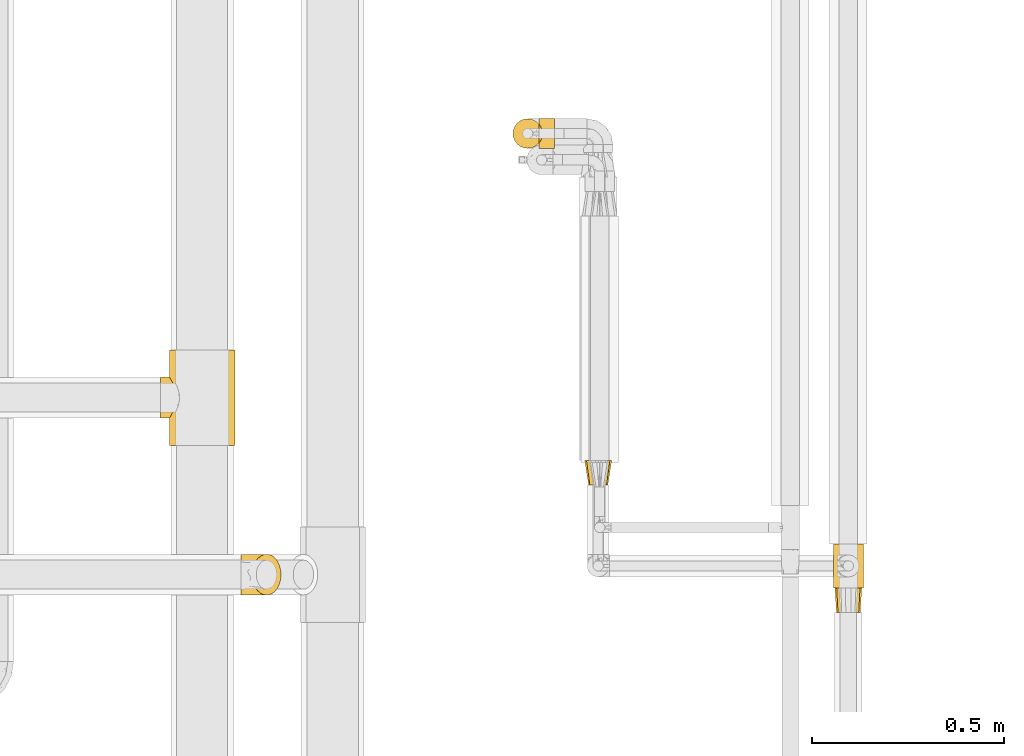
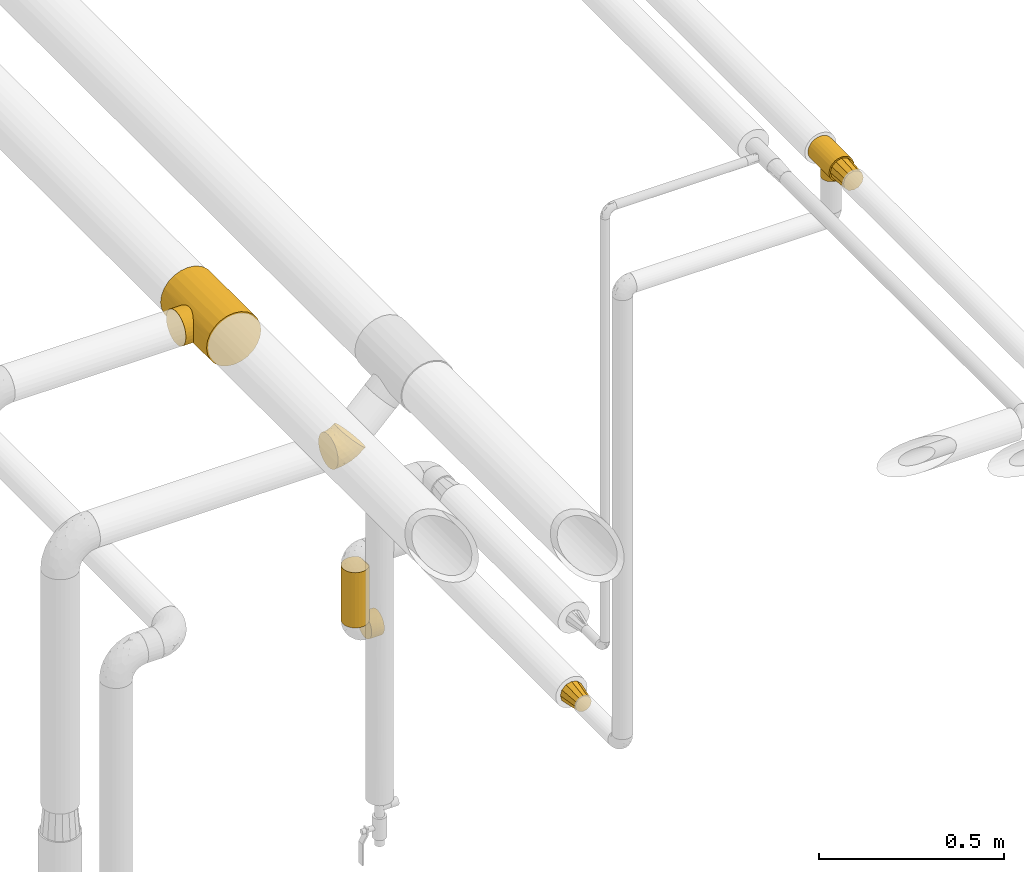
# One storey, part 113 of 827: 7 coverings.
"""IFC2X3 building model written with IfcOpenShell, lengths in millimetres."""

from ifc_helpers import new_model, entity, si_unit, converted_unit, derived_unit, direction, frame, origin, place, context, subcontext, project, spatial, faceted_brep, element, save


model = new_model("IFC2X3")

# Units and contexts
model_context = context("Model", 3, precision=0.01, world=origin(), true_north=direction((6.12303176911189e-17, 1.0)))
body_context = subcontext(model_context, "Body", "Model", "MODEL_VIEW")
ifc_project = project(units=[si_unit("LENGTHUNIT", "METRE", prefix="MILLI"), si_unit("AREAUNIT", "SQUARE_METRE"), si_unit("VOLUMEUNIT", "CUBIC_METRE"), converted_unit("PLANEANGLEUNIT", "DEGREE", entity("IfcRatioMeasure", 0.0174532925199433), si_unit("PLANEANGLEUNIT", "RADIAN"), dimensions=[0, 0, 0, 0, 0, 0, 0]), si_unit("MASSUNIT", "GRAM", prefix="KILO"), derived_unit("MASSDENSITYUNIT", [(si_unit("MASSUNIT", "GRAM", prefix="KILO"), 1), (si_unit("LENGTHUNIT", "METRE"), -3)]), derived_unit("MOMENTOFINERTIAUNIT", [(si_unit("LENGTHUNIT", "METRE"), 4)]), si_unit("TIMEUNIT", "SECOND"), si_unit("FREQUENCYUNIT", "HERTZ"), si_unit("THERMODYNAMICTEMPERATUREUNIT", "DEGREE_CELSIUS"), derived_unit("THERMALTRANSMITTANCEUNIT", [(si_unit("MASSUNIT", "GRAM", prefix="KILO"), 1), (si_unit("THERMODYNAMICTEMPERATUREUNIT", "KELVIN"), -1), (si_unit("TIMEUNIT", "SECOND"), -3)]), derived_unit("VOLUMETRICFLOWRATEUNIT", [(si_unit("LENGTHUNIT", "METRE"), 3), (si_unit("TIMEUNIT", "SECOND"), -1)]), derived_unit("MASSFLOWRATEUNIT", [(si_unit("MASSUNIT", "GRAM", prefix="KILO"), 1), (si_unit("TIMEUNIT", "SECOND"), -1)]), derived_unit("ROTATIONALFREQUENCYUNIT", [(si_unit("TIMEUNIT", "SECOND"), -1)]), si_unit("ELECTRICCURRENTUNIT", "AMPERE"), si_unit("ELECTRICVOLTAGEUNIT", "VOLT"), si_unit("POWERUNIT", "WATT"), si_unit("FORCEUNIT", "NEWTON", prefix="KILO"), si_unit("ILLUMINANCEUNIT", "LUX"), si_unit("LUMINOUSFLUXUNIT", "LUMEN"), si_unit("LUMINOUSINTENSITYUNIT", "CANDELA"), derived_unit("USERDEFINED", [(si_unit("MASSUNIT", "GRAM", prefix="KILO"), -1), (si_unit("LENGTHUNIT", "METRE"), -2), (si_unit("TIMEUNIT", "SECOND"), 3), (si_unit("LUMINOUSFLUXUNIT", "LUMEN"), 1)]), derived_unit("LINEARVELOCITYUNIT", [(si_unit("LENGTHUNIT", "METRE"), 1), (si_unit("TIMEUNIT", "SECOND"), -1)]), si_unit("PRESSUREUNIT", "PASCAL"), derived_unit("USERDEFINED", [(si_unit("LENGTHUNIT", "METRE"), -2), (si_unit("MASSUNIT", "GRAM", prefix="KILO"), 1), (si_unit("TIMEUNIT", "SECOND"), -2)]), derived_unit("LINEARFORCEUNIT", [(si_unit("MASSUNIT", "GRAM", prefix="KILO"), 1), (si_unit("LENGTHUNIT", "METRE"), 1), (si_unit("TIMEUNIT", "SECOND"), -2), (si_unit("LENGTHUNIT", "METRE"), -1)]), derived_unit("PLANARFORCEUNIT", [(si_unit("MASSUNIT", "GRAM", prefix="KILO"), 1), (si_unit("LENGTHUNIT", "METRE"), 1), (si_unit("TIMEUNIT", "SECOND"), -2), (si_unit("LENGTHUNIT", "METRE"), -2)])], contexts=[model_context])

# Site, building, storey
site_placement = place(None, origin())
site = spatial("IfcSite", under=ifc_project, at=site_placement, CompositionType="ELEMENT")
building_placement = place(site_placement, origin())
building = spatial("IfcBuilding", under=site, at=building_placement, CompositionType="ELEMENT")
storey_placement = place(building_placement, frame((0.0, 0.0, 28200.0)))
storey = spatial("IfcBuildingStorey", under=building, at=storey_placement, Name="08", CompositionType="ELEMENT", Elevation=28200.0)

# Coverings
covering_1_placement = place(storey_placement, frame((23473.64, 10765.39, 2939.48)))
element("IfcCovering", 1, at=covering_1_placement, inside=storey, Name=":ADSK_", ObjectType=":ADSK_", PredefinedType="INSULATION", context=body_context, shape_type="Brep", body=[
    faceted_brep([(60.32, 0.0, 90.9), (50.88, 0.0, 94.82), (40.75, 0.0, 96.15), (30.61, 0.0, 94.82), (21.17, 0.0, 90.9), (13.06, 0.0, 84.68), (6.84, 0.0, 76.57), (2.93, 0.0, 67.13), (1.6, 0.0, 57.0), (2.93, 0.0, 46.87), (6.84, 0.0, 37.42), (13.06, 0.0, 29.32), (17.12, 0.0, 26.21), (21.17, 0.0, 23.1), (25.89, 0.0, 21.14), (30.61, 0.0, 19.18), (35.68, 0.0, 18.52), (40.75, 0.0, 17.85), (45.81, 0.0, 18.52), (50.88, 0.0, 19.18), (55.6, 0.0, 21.14), (60.32, 0.0, 23.1), (64.37, 0.0, 26.21), (68.43, 0.0, 29.32), (74.65, 0.0, 37.42), (78.56, 0.0, 46.87), (79.9, 0.0, 57.0), (78.56, 0.0, 67.13), (74.65, 0.0, 76.57), (68.43, 0.0, 84.68), (2.93, 114.0, 46.87), (1.6, 114.0, 57.0), (2.93, 114.0, 67.13), (6.84, 114.0, 76.57), (13.06, 114.0, 84.68), (21.17, 114.0, 90.9), (30.61, 114.0, 94.82), (40.75, 114.0, 96.15), (50.88, 114.0, 94.82), (60.32, 114.0, 90.9), (68.43, 114.0, 84.68), (74.65, 114.0, 76.57), (78.56, 114.0, 67.13), (79.9, 114.0, 57.0), (78.56, 114.0, 46.87), (74.65, 114.0, 37.42), (68.43, 114.0, 29.32), (64.37, 114.0, 26.21), (60.32, 114.0, 23.1), (55.6, 114.0, 21.14), (50.88, 114.0, 19.18), (45.81, 114.0, 18.52), (40.75, 114.0, 17.85), (35.68, 114.0, 18.52), (30.61, 114.0, 19.18), (25.89, 114.0, 21.14), (21.17, 114.0, 23.1), (17.12, 114.0, 26.21), (13.06, 114.0, 29.32), (6.84, 114.0, 37.42), (15.2, 69.53, 27.33), (18.49, 74.73, 24.79), (28.07, 31.53, 19.96), (13.06, 63.55, 29.32), (12.3, 57.0, 30.11), (13.06, 50.45, 29.32), (40.75, 28.55, 17.85), (34.16, 29.32, 18.41), (15.2, 44.47, 27.33), (18.49, 39.27, 24.79), (22.81, 79.08, 22.2), (28.07, 82.47, 19.96), (34.16, 84.68, 18.41), (40.75, 85.45, 17.85), (22.81, 34.92, 22.2), (47.33, 84.68, 18.41), (58.68, 79.08, 22.2), (53.42, 82.47, 19.96), (47.33, 29.32, 18.41), (58.68, 34.92, 22.2), (53.42, 31.53, 19.96), (63.0, 39.27, 24.79), (63.0, 74.73, 24.79), (66.29, 69.53, 27.33), (68.43, 63.55, 29.32), (69.2, 57.0, 30.11), (66.29, 44.47, 27.33), (68.43, 50.45, 29.32), (12.3, 57.0, 0.0), (13.26, 64.36, 0.0), (16.11, 71.22, 0.0), (20.63, 77.12, 0.0), (26.52, 81.64, 0.0), (33.38, 84.48, 0.0), (40.75, 85.45, 0.0), (48.11, 84.48, 0.0), (54.97, 81.64, 0.0), (60.86, 77.12, 0.0), (65.38, 71.22, 0.0), (68.23, 64.36, 0.0), (69.2, 57.0, 0.0), (68.23, 49.64, 0.0), (65.38, 42.77, 0.0), (60.86, 36.88, 0.0), (54.97, 32.36, 0.0), (48.11, 29.52, 0.0), (40.75, 28.55, 0.0), (33.38, 29.52, 0.0), (26.52, 32.36, 0.0), (20.63, 36.88, 0.0), (16.11, 42.77, 0.0), (13.26, 49.64, 0.0)], [[[0, 1, 2, 3, 4, 5, 6, 7, 8, 9, 10, 11, 12, 13, 14, 15, 16, 17, 18, 19, 20, 21, 22, 23, 24, 25, 26, 27, 28, 29]], [[30, 31, 32, 33, 34, 35, 36, 37, 38, 39, 40, 41, 42, 43, 44, 45, 46, 47, 48, 49, 50, 51, 52, 53, 54, 55, 56, 57, 58, 59]], [[35, 34, 5, 4]], [[3, 2, 37, 36]], [[36, 35, 4, 3]], [[6, 33, 32, 7]], [[7, 32, 31, 8]], [[5, 34, 33, 6]], [[30, 9, 8, 31]], [[59, 10, 9, 30]], [[57, 60, 58]], [[61, 57, 56]], [[62, 15, 14]], [[60, 63, 58]], [[60, 57, 61]], [[59, 58, 64]], [[58, 63, 64]], [[64, 65, 11]], [[66, 16, 67]], [[12, 68, 69]], [[68, 11, 65]], [[69, 13, 12]], [[64, 11, 10]], [[64, 10, 59]], [[70, 55, 71]], [[55, 70, 56]], [[71, 55, 54]], [[72, 54, 53]], [[52, 73, 53]], [[66, 17, 16]], [[72, 53, 73]], [[54, 72, 71]], [[69, 74, 13]], [[74, 14, 13]], [[14, 74, 62]], [[12, 11, 68]], [[16, 15, 67]], [[67, 15, 62]], [[70, 61, 56]], [[52, 51, 73]], [[66, 18, 17]], [[75, 51, 50]], [[48, 76, 49]], [[77, 49, 76]], [[50, 77, 75]], [[78, 18, 66]], [[79, 21, 20]], [[20, 19, 80]], [[21, 79, 81]], [[80, 19, 78]], [[82, 76, 48]], [[47, 83, 82]], [[83, 47, 46]], [[83, 46, 84]], [[77, 50, 49]], [[24, 45, 44, 25]], [[45, 85, 46]], [[46, 85, 84]], [[44, 43, 26, 25]], [[78, 19, 18]], [[86, 87, 23]], [[79, 20, 80]], [[81, 22, 21]], [[22, 86, 23]], [[87, 85, 23]], [[73, 51, 75]], [[85, 24, 23]], [[85, 45, 24]], [[86, 22, 81]], [[82, 48, 47]], [[27, 42, 41, 28]], [[28, 41, 40, 29]], [[43, 42, 27, 26]], [[0, 39, 38, 1]], [[1, 38, 37, 2]], [[29, 40, 39, 0]], [[88, 89, 90, 91, 92, 93, 94, 95, 96, 97, 98, 99, 100, 101, 102, 103, 104, 105, 106, 107, 108, 109, 110, 111]], [[72, 94, 93]], [[71, 93, 92]], [[72, 73, 94]], [[70, 71, 92]], [[72, 93, 71]], [[92, 91, 70]], [[61, 91, 90]], [[60, 90, 89]], [[63, 89, 88]], [[61, 90, 60]], [[63, 60, 89]], [[64, 63, 88]], [[91, 61, 70]], [[65, 88, 111]], [[68, 111, 110]], [[64, 88, 65]], [[65, 111, 68]], [[110, 69, 68]], [[110, 109, 69]], [[109, 108, 74]], [[108, 107, 62]], [[67, 107, 106]], [[62, 74, 108]], [[66, 67, 106]], [[62, 107, 67]], [[109, 74, 69]], [[78, 106, 105]], [[80, 105, 104]], [[78, 66, 106]], [[79, 80, 104]], [[78, 105, 80]], [[104, 103, 79]], [[103, 102, 81]], [[102, 101, 86]], [[87, 101, 100]], [[81, 102, 86]], [[87, 86, 101]], [[85, 87, 100]], [[103, 81, 79]], [[84, 100, 99]], [[83, 99, 98]], [[85, 100, 84]], [[84, 99, 83]], [[98, 82, 83]], [[98, 97, 82]], [[76, 97, 96]], [[95, 94, 75]], [[77, 96, 95]], [[77, 76, 96]], [[73, 75, 94]], [[77, 95, 75]], [[97, 76, 82]]]),
])
covering_2_placement = place(storey_placement, frame((23477.79, 10701.39, 2959.89)))
element("IfcCovering", 2, at=covering_2_placement, inside=storey, Name=":ADSK_", ObjectType=":ADSK_", PredefinedType="INSULATION", context=body_context, shape_type="Brep", body=[
    faceted_brep([(21.1, 0.0, 63.44), (15.42, 0.0, 57.77), (9.75, 0.0, 52.1), (7.67, 0.0, 44.35), (5.6, 0.0, 36.6), (7.67, 0.0, 28.85), (9.75, 0.0, 21.1), (15.42, 0.0, 15.42), (21.1, 0.0, 9.75), (28.85, 0.0, 7.67), (36.6, 0.0, 5.6), (44.35, 0.0, 7.67), (52.1, 0.0, 9.75), (57.77, 0.0, 15.42), (63.44, 0.0, 21.1), (65.52, 0.0, 28.85), (67.6, 0.0, 36.6), (65.52, 0.0, 44.35), (63.44, 0.0, 52.1), (57.77, 0.0, 57.77), (52.1, 0.0, 63.44), (44.35, 0.0, 65.52), (36.6, 0.0, 67.6), (28.85, 0.0, 65.52), (69.15, 64.0, 45.72), (71.6, 64.0, 36.6), (69.15, 64.0, 27.47), (66.91, 64.0, 19.1), (60.5, 64.0, 12.69), (54.1, 64.0, 6.28), (45.72, 64.0, 4.04), (36.6, 64.0, 1.6), (27.47, 64.0, 4.04), (19.1, 64.0, 6.28), (12.69, 64.0, 12.69), (6.28, 64.0, 19.1), (4.04, 64.0, 27.47), (1.6, 64.0, 36.6), (4.04, 64.0, 45.72), (6.28, 64.0, 54.1), (12.69, 64.0, 60.5), (19.1, 64.0, 66.91), (27.47, 64.0, 69.15), (36.6, 64.0, 71.6), (45.72, 64.0, 69.15), (54.1, 64.0, 66.91), (60.5, 64.0, 60.5), (66.91, 64.0, 54.1)], [[[0, 1, 2, 3, 4, 5, 6, 7, 8, 9, 10, 11, 12, 13, 14, 15, 16, 17, 18, 19, 20, 21, 22, 23]], [[24, 25, 26, 27, 28, 29, 30, 31, 32, 33, 34, 35, 36, 37, 38, 39, 40, 41, 42, 43, 44, 45, 46, 47]], [[20, 45, 44, 43, 22, 21]], [[47, 46, 45, 20, 19, 18]], [[17, 16, 25, 24, 47, 18]], [[2, 39, 38, 37, 4, 3]], [[41, 40, 39, 2, 1, 0]], [[23, 22, 43, 42, 41, 0]], [[8, 33, 32, 31, 10, 9]], [[35, 34, 33, 8, 7, 6]], [[5, 4, 37, 36, 35, 6]], [[14, 27, 26, 25, 16, 15]], [[29, 28, 27, 14, 13, 12]], [[11, 10, 31, 30, 29, 12]]]),
])
covering_3_placement = place(storey_placement, frame((22827.77, 11032.39, 1263.97)))
element("IfcCovering", 3, at=covering_3_placement, inside=storey, Name=":ADSK_", ObjectType=":ADSK_", PredefinedType="INSULATION", context=body_context, shape_type="Brep", body=[
    faceted_brep([(66.91, 64.0, 19.1), (60.5, 64.0, 12.69), (54.1, 64.0, 6.28), (45.21, 64.0, 3.9), (36.6, 64.0, 1.6), (27.98, 64.0, 3.9), (19.1, 64.0, 6.28), (12.69, 64.0, 12.69), (6.28, 64.0, 19.1), (3.9, 64.0, 27.98), (1.6, 64.0, 36.6), (3.9, 64.0, 45.21), (6.28, 64.0, 54.1), (12.69, 64.0, 60.5), (19.1, 64.0, 66.91), (27.98, 64.0, 69.29), (36.6, 64.0, 71.6), (45.21, 64.0, 69.29), (54.1, 64.0, 66.91), (60.5, 64.0, 60.5), (66.91, 64.0, 54.1), (69.29, 64.0, 45.21), (71.6, 64.0, 36.6), (69.29, 64.0, 27.98), (24.1, 0.0, 58.25), (19.52, 0.0, 53.67), (14.94, 0.0, 49.1), (13.27, 0.0, 42.85), (11.6, 0.0, 36.6), (13.27, 0.0, 30.35), (14.94, 0.0, 24.1), (19.52, 0.0, 19.52), (24.1, 0.0, 14.94), (30.35, 0.0, 13.27), (36.6, 0.0, 11.6), (42.85, 0.0, 13.27), (49.1, 0.0, 14.94), (53.67, 0.0, 19.52), (58.25, 0.0, 24.1), (59.92, 0.0, 30.35), (61.6, 0.0, 36.6), (59.92, 0.0, 42.85), (58.25, 0.0, 49.1), (53.67, 0.0, 53.67), (49.1, 0.0, 58.25), (42.85, 0.0, 59.92), (36.6, 0.0, 61.6), (30.35, 0.0, 59.92)], [[[0, 1, 2, 3, 4, 5, 6, 7, 8, 9, 10, 11, 12, 13, 14, 15, 16, 17, 18, 19, 20, 21, 22, 23]], [[24, 25, 26, 27, 28, 29, 30, 31, 32, 33, 34, 35, 36, 37, 38, 39, 40, 41, 42, 43, 44, 45, 46, 47]], [[0, 23, 22, 40, 39, 38]], [[1, 0, 38, 37, 36, 2]], [[3, 2, 36, 35, 34, 4]], [[6, 5, 4, 34, 33, 32]], [[7, 6, 32, 31, 30, 8]], [[9, 8, 30, 29, 28, 10]], [[12, 11, 10, 28, 27, 26]], [[13, 12, 26, 25, 24, 14]], [[15, 14, 24, 47, 46, 16]], [[18, 17, 16, 46, 45, 44]], [[19, 18, 44, 43, 42, 20]], [[21, 20, 42, 41, 40, 22]]]),
])
covering_4_placement = place(storey_placement, frame((21933.88, 10745.0, 2545.36)))
element("IfcCovering", 4, at=covering_4_placement, inside=storey, Name=":ADSK_", ObjectType=":ADSK_", PredefinedType="INSULATION", context=body_context, shape_type="Brep", body=[
    faceted_brep([(32.2, 42.84, 119.04), (34.98, 31.62, 116.26), (39.45, 21.56, 111.79), (45.39, 13.16, 105.85), (52.5, 6.84, 98.74), (60.43, 2.92, 90.81), (68.77, 1.6, 82.47), (77.12, 2.93, 74.12), (85.05, 6.85, 66.19), (92.16, 13.18, 59.08), (98.1, 21.58, 53.14), (102.57, 31.64, 48.67), (105.34, 42.85, 45.9), (106.28, 54.65, 44.96), (105.34, 66.46, 45.9), (102.56, 77.67, 48.68), (98.09, 87.73, 53.15), (92.15, 96.13, 59.09), (85.04, 102.45, 66.2), (77.11, 106.37, 74.13), (68.77, 107.7, 82.47), (60.42, 106.36, 90.82), (52.49, 102.44, 98.75), (45.38, 96.11, 105.86), (39.44, 87.71, 111.8), (34.97, 77.65, 116.27), (32.2, 66.44, 119.04), (31.26, 54.65, 119.98), (1.6, 68.38, 105.89), (1.6, 81.17, 100.59), (1.6, 92.16, 92.16), (1.6, 100.59, 81.17), (1.6, 105.89, 68.38), (1.6, 107.7, 54.65), (1.6, 105.89, 40.91), (1.6, 100.59, 28.12), (1.6, 92.16, 17.13), (1.6, 81.17, 8.7), (1.6, 68.38, 3.4), (1.6, 54.65, 1.6), (1.6, 40.91, 3.4), (1.6, 28.12, 8.7), (1.6, 17.13, 17.13), (1.6, 8.7, 28.12), (1.6, 3.4, 40.91), (1.6, 1.6, 54.65), (1.6, 3.4, 68.38), (1.6, 8.7, 81.17), (1.6, 17.13, 92.16), (1.6, 28.12, 100.59), (1.6, 40.91, 105.89), (1.6, 54.65, 107.7), (72.63, 17.98, 36.8), (39.91, 54.65, 6.64), (28.07, 23.07, 14.58), (75.62, 54.65, 21.43), (46.17, 40.45, 10.5), (44.28, 4.24, 46.61), (65.61, 5.7, 53.56), (44.57, 13.79, 28.19), (45.63, 8.23, 37.28), (23.02, 6.11, 35.23), (78.63, 37.78, 26.45), (26.18, 1.6, 57.88), (14.71, 1.6, 56.37), (53.39, 20.14, 24.66), (81.53, 27.08, 34.31), (56.27, 27.84, 19.92), (69.64, 10.41, 45.64), (27.26, 32.58, 8.72), (58.28, 1.6, 74.42), (49.1, 1.6, 67.37), (37.64, 1.6, 62.63), (17.93, 8.16, 82.16), (17.26, 4.17, 72.54), (29.81, 6.51, 82.64), (47.76, 3.36, 82.55), (37.34, 2.83, 74.03), (40.73, 8.06, 92.07), (21.92, 23.78, 101.94), (18.26, 13.97, 91.02), (32.65, 15.16, 98.81), (22.95, 35.68, 109.52), (11.79, 33.15, 104.28), (14.09, 43.74, 108.41), (30.85, 25.23, 108.05), (17.65, 54.65, 110.89), (23.74, 46.23, 113.23), (11.8, 24.78, 99.52), (13.14, 65.25, 108.2), (22.95, 73.59, 109.53), (11.79, 76.14, 104.28), (32.64, 94.11, 98.82), (17.27, 105.12, 72.54), (29.8, 102.77, 82.66), (30.59, 106.44, 71.32), (11.79, 84.51, 99.52), (21.91, 85.49, 101.95), (14.71, 107.7, 56.37), (13.92, 100.53, 82.39), (18.26, 95.3, 91.05), (26.18, 107.7, 57.88), (40.73, 101.22, 92.08), (30.85, 84.04, 108.06), (47.74, 105.93, 82.56), (37.64, 107.7, 62.63), (49.1, 107.7, 67.37), (23.15, 63.57, 112.78), (58.28, 107.7, 74.42), (23.02, 103.18, 35.23), (78.63, 71.52, 26.45), (81.52, 82.23, 34.32), (72.62, 91.32, 36.81), (69.62, 98.89, 45.65), (45.63, 101.06, 37.28), (44.53, 95.5, 28.17), (28.06, 86.22, 14.58), (56.26, 81.47, 19.93), (27.25, 76.72, 8.72), (46.14, 68.85, 10.49), (65.61, 103.6, 53.58), (44.28, 105.05, 46.61)], [[[0, 1, 2, 3, 4, 5, 6, 7, 8, 9, 10, 11, 12, 13, 14, 15, 16, 17, 18, 19, 20, 21, 22, 23, 24, 25, 26, 27]], [[28, 29, 30, 31, 32, 33, 34, 35, 36, 37, 38, 39, 40, 41, 42, 43, 44, 45, 46, 47, 48, 49, 50, 51]], [[52, 10, 9]], [[40, 39, 53]], [[41, 54, 42]], [[53, 55, 56]], [[7, 57, 58]], [[59, 60, 61]], [[55, 12, 62]], [[59, 43, 42]], [[44, 63, 64, 45]], [[63, 44, 57]], [[43, 61, 44]], [[52, 65, 66]], [[54, 59, 42]], [[59, 65, 52]], [[62, 56, 55]], [[62, 67, 56]], [[52, 9, 68]], [[66, 11, 10]], [[66, 62, 11]], [[12, 55, 13]], [[54, 67, 65]], [[69, 54, 41]], [[40, 56, 69]], [[62, 66, 67]], [[68, 9, 8]], [[7, 6, 70, 71]], [[57, 71, 72, 63]], [[57, 7, 71]], [[59, 52, 68]], [[58, 68, 8]], [[60, 57, 61]], [[40, 53, 56]], [[52, 66, 10]], [[62, 12, 11]], [[40, 69, 41]], [[67, 54, 69]], [[67, 69, 56]], [[7, 58, 8]], [[60, 58, 57]], [[59, 61, 43]], [[57, 44, 61]], [[59, 68, 60]], [[58, 60, 68]], [[54, 65, 59]], [[66, 65, 67]], [[73, 48, 47]], [[63, 74, 64]], [[47, 74, 73]], [[74, 75, 73]], [[70, 76, 71]], [[75, 77, 78]], [[79, 80, 81]], [[79, 82, 83]], [[84, 51, 50]], [[49, 83, 50]], [[75, 81, 80]], [[3, 78, 4]], [[1, 85, 2]], [[82, 84, 83]], [[78, 77, 76]], [[77, 63, 72, 71]], [[85, 81, 2]], [[76, 5, 4]], [[78, 76, 4]], [[76, 70, 5]], [[77, 74, 63]], [[74, 46, 64]], [[47, 46, 74]], [[86, 87, 27]], [[86, 84, 87]], [[0, 82, 1]], [[2, 81, 3]], [[80, 88, 48]], [[79, 85, 82]], [[83, 88, 79]], [[70, 6, 5]], [[3, 81, 78]], [[81, 75, 78]], [[76, 77, 71]], [[83, 49, 88]], [[0, 87, 82]], [[51, 84, 86]], [[50, 83, 84]], [[82, 87, 84]], [[27, 87, 0]], [[82, 85, 1]], [[81, 85, 79]], [[48, 88, 49]], [[80, 79, 88]], [[46, 45, 64]], [[75, 80, 73]], [[73, 80, 48]], [[74, 77, 75]], [[89, 90, 91]], [[24, 23, 92]], [[86, 89, 51]], [[93, 94, 95]], [[96, 91, 97]], [[91, 29, 28]], [[93, 98, 32]], [[30, 99, 31]], [[93, 32, 31]], [[30, 29, 96]], [[92, 100, 97]], [[31, 99, 93]], [[93, 95, 101]], [[92, 94, 100]], [[25, 90, 26]], [[23, 102, 92]], [[25, 103, 90]], [[21, 104, 22]], [[92, 97, 103]], [[105, 101, 95, 106]], [[91, 96, 29]], [[103, 25, 24]], [[30, 100, 99]], [[104, 102, 22]], [[107, 90, 89]], [[102, 23, 22]], [[106, 104, 108]], [[104, 21, 108]], [[94, 93, 99]], [[102, 104, 94]], [[21, 20, 108]], [[107, 27, 26]], [[94, 92, 102]], [[95, 104, 106]], [[89, 91, 28]], [[97, 91, 90]], [[51, 89, 28]], [[89, 86, 107]], [[27, 107, 86]], [[26, 90, 107]], [[92, 103, 24]], [[90, 103, 97]], [[97, 100, 96]], [[30, 96, 100]], [[98, 93, 101]], [[98, 33, 32]], [[94, 99, 100]], [[104, 95, 94]], [[35, 34, 109]], [[110, 111, 15]], [[34, 33, 98, 101]], [[112, 113, 17]], [[114, 115, 109]], [[116, 115, 117]], [[39, 38, 53]], [[117, 118, 116]], [[110, 119, 117]], [[115, 116, 36]], [[35, 115, 36]], [[37, 116, 118]], [[118, 117, 119]], [[18, 120, 19]], [[121, 101, 105, 106]], [[112, 111, 117]], [[19, 106, 108, 20]], [[36, 116, 37]], [[112, 17, 16]], [[53, 38, 119]], [[117, 115, 112]], [[121, 34, 101]], [[118, 38, 37]], [[113, 18, 17]], [[119, 110, 55]], [[111, 16, 15]], [[14, 13, 55]], [[14, 55, 110]], [[120, 18, 113]], [[111, 110, 117]], [[119, 55, 53]], [[14, 110, 15]], [[111, 112, 16]], [[19, 121, 106]], [[112, 115, 113]], [[109, 115, 35]], [[38, 118, 119]], [[114, 120, 113]], [[19, 120, 121]], [[34, 121, 109]], [[109, 121, 114]], [[120, 114, 121]], [[113, 115, 114]]]),
])
covering_5_placement = place(storey_placement, frame((21727.11, 11135.65, 2713.55)))
element("IfcCovering", 5, at=covering_5_placement, inside=storey, Name=":ADSK_", ObjectType=":ADSK_", PredefinedType="INSULATION", context=body_context, shape_type="Brep", body=[
    faceted_brep([(181.48, 0.0, 44.02), (189.96, 0.0, 64.48), (192.85, 0.0, 86.45), (189.96, 0.0, 108.41), (181.48, 0.0, 128.87), (168.0, 0.0, 146.44), (150.42, 0.0, 159.93), (129.96, 0.0, 168.4), (108.0, 0.0, 171.3), (86.04, 0.0, 168.4), (65.58, 0.0, 159.93), (48.0, 0.0, 146.44), (34.52, 0.0, 128.87), (30.28, 0.0, 118.64), (26.04, 0.0, 108.41), (24.6, 0.0, 97.43), (23.15, 0.0, 86.45), (24.6, 0.0, 75.46), (26.04, 0.0, 64.48), (30.28, 0.0, 54.25), (34.52, 0.0, 44.02), (48.0, 0.0, 26.45), (65.58, 0.0, 12.96), (86.04, 0.0, 4.49), (108.0, 0.0, 1.6), (129.96, 0.0, 4.49), (150.42, 0.0, 12.96), (168.0, 0.0, 26.45), (108.0, 248.0, 171.3), (129.96, 248.0, 168.4), (150.42, 248.0, 159.93), (168.0, 248.0, 146.44), (181.48, 248.0, 128.87), (189.96, 248.0, 108.41), (192.85, 248.0, 86.45), (189.96, 248.0, 64.48), (181.48, 248.0, 44.02), (168.0, 248.0, 26.45), (150.42, 248.0, 12.96), (129.96, 248.0, 4.49), (108.0, 248.0, 1.6), (86.04, 248.0, 4.49), (65.58, 248.0, 12.96), (48.0, 248.0, 26.45), (34.52, 248.0, 44.02), (30.28, 248.0, 54.25), (26.04, 248.0, 64.48), (24.6, 248.0, 75.46), (23.15, 248.0, 86.45), (24.6, 248.0, 97.43), (26.04, 248.0, 108.41), (30.28, 248.0, 118.64), (34.52, 248.0, 128.87), (48.0, 248.0, 146.44), (65.58, 248.0, 159.93), (86.04, 248.0, 168.4), (37.8, 147.29, 134.11), (26.44, 76.39, 109.85), (29.95, 82.7, 119.74), (40.69, 136.08, 138.1), (24.02, 175.65, 98.56), (41.78, 124.0, 139.5), (40.69, 111.92, 138.1), (23.15, 70.95, 86.45), (24.02, 72.35, 98.56), (37.8, 100.71, 134.11), (29.95, 165.3, 119.74), (33.96, 157.11, 127.9), (26.44, 171.61, 109.85), (23.15, 177.05, 86.45), (33.96, 90.89, 127.9), (24.02, 175.65, 74.33), (26.44, 171.61, 63.04), (33.96, 157.11, 45.0), (29.95, 165.3, 53.16), (24.02, 72.35, 74.33), (26.44, 76.39, 63.04), (29.95, 82.7, 53.16), (33.96, 90.89, 45.0), (37.8, 147.29, 38.78), (40.69, 136.08, 34.79), (41.78, 124.0, 33.4), (37.8, 100.71, 38.78), (40.69, 111.92, 34.79), (0.0, 124.0, 139.5), (0.0, 137.73, 137.69), (0.0, 150.52, 132.39), (0.0, 161.51, 123.96), (0.0, 169.94, 112.97), (0.0, 175.24, 100.18), (0.0, 177.05, 86.45), (0.0, 175.24, 72.71), (0.0, 169.94, 59.92), (0.0, 161.51, 48.93), (0.0, 150.52, 40.5), (0.0, 137.73, 35.2), (0.0, 124.0, 33.4), (0.0, 110.27, 35.2), (0.0, 97.47, 40.5), (0.0, 86.49, 48.93), (0.0, 78.06, 59.92), (0.0, 72.76, 72.71), (0.0, 70.95, 86.45), (0.0, 72.76, 100.18), (0.0, 78.06, 112.97), (0.0, 86.49, 123.96), (0.0, 97.47, 132.39), (0.0, 110.27, 137.69)], [[[0, 1, 2, 3, 4, 5, 6, 7, 8, 9, 10, 11, 12, 13, 14, 15, 16, 17, 18, 19, 20, 21, 22, 23, 24, 25, 26, 27]], [[28, 29, 30, 31, 32, 33, 34, 35, 36, 37, 38, 39, 40, 41, 42, 43, 44, 45, 46, 47, 48, 49, 50, 51, 52, 53, 54, 55]], [[32, 31, 5, 4]], [[2, 34, 33, 3]], [[3, 33, 32, 4]], [[6, 30, 29, 7]], [[7, 29, 28, 8]], [[5, 31, 30, 6]], [[55, 9, 8, 28]], [[54, 10, 9, 55]], [[53, 52, 56]], [[57, 13, 58]], [[56, 59, 53]], [[60, 50, 49]], [[54, 53, 11, 10]], [[53, 59, 61]], [[61, 62, 11]], [[63, 15, 64]], [[11, 65, 12]], [[65, 11, 62]], [[66, 52, 51]], [[11, 53, 61]], [[56, 52, 67]], [[67, 52, 66]], [[66, 51, 68]], [[48, 69, 49]], [[63, 16, 15]], [[60, 49, 69]], [[50, 60, 68]], [[50, 68, 51]], [[70, 58, 12]], [[13, 57, 14]], [[58, 13, 12]], [[12, 65, 70]], [[15, 14, 64]], [[64, 14, 57]], [[48, 47, 69]], [[63, 17, 16]], [[71, 47, 46]], [[46, 72, 71]], [[46, 45, 72]], [[44, 73, 74]], [[74, 45, 44]], [[75, 17, 63]], [[76, 19, 18]], [[76, 77, 19]], [[76, 18, 75]], [[77, 78, 20]], [[79, 43, 80]], [[43, 79, 44]], [[69, 47, 71]], [[72, 45, 74]], [[42, 41, 23, 22]], [[21, 43, 42, 22]], [[80, 43, 81]], [[23, 41, 40, 24]], [[21, 82, 83]], [[75, 18, 17]], [[21, 20, 82]], [[20, 78, 82]], [[83, 81, 21]], [[77, 20, 19]], [[81, 43, 21]], [[79, 73, 44]], [[25, 39, 38, 26]], [[26, 38, 37, 27]], [[40, 39, 25, 24]], [[0, 36, 35, 1]], [[1, 35, 34, 2]], [[27, 37, 36, 0]], [[84, 85, 86, 87, 88, 89, 90, 91, 92, 93, 94, 95, 96, 97, 98, 99, 100, 101, 102, 103, 104, 105, 106, 107]], [[60, 90, 89]], [[68, 89, 88]], [[60, 69, 90]], [[66, 68, 88]], [[60, 89, 68]], [[88, 87, 66]], [[67, 87, 86]], [[56, 86, 85]], [[59, 85, 84]], [[67, 86, 56]], [[59, 56, 85]], [[61, 59, 84]], [[87, 67, 66]], [[62, 84, 107]], [[65, 107, 106]], [[61, 84, 62]], [[62, 107, 65]], [[106, 70, 65]], [[106, 105, 70]], [[105, 104, 58]], [[104, 103, 57]], [[64, 103, 102]], [[57, 58, 104]], [[63, 64, 102]], [[57, 103, 64]], [[105, 58, 70]], [[75, 102, 101]], [[76, 101, 100]], [[75, 63, 102]], [[77, 76, 100]], [[75, 101, 76]], [[100, 99, 77]], [[99, 98, 78]], [[98, 97, 82]], [[83, 97, 96]], [[78, 98, 82]], [[83, 82, 97]], [[81, 83, 96]], [[99, 78, 77]], [[80, 96, 95]], [[79, 95, 94]], [[81, 96, 80]], [[80, 95, 79]], [[94, 73, 79]], [[94, 93, 73]], [[93, 92, 74]], [[92, 91, 72]], [[71, 91, 90]], [[72, 74, 92]], [[69, 71, 90]], [[72, 91, 71]], [[93, 74, 73]]]),
])
covering_6_placement = place(storey_placement, frame((22641.07, 11906.0, 1085.82)))
element("IfcCovering", 6, at=covering_6_placement, inside=storey, Name=":ADSK_", ObjectType=":ADSK_", PredefinedType="INSULATION", context=body_context, shape_type="Brep", body=[
    faceted_brep([(6.74, 20.8, 1.6), (2.9, 30.06, 1.6), (1.6, 40.0, 1.6), (2.9, 49.93, 1.6), (6.74, 59.2, 1.6), (12.84, 67.15, 1.6), (20.8, 73.25, 1.6), (30.06, 77.09, 1.6), (40.0, 78.4, 1.6), (48.2, 77.51, 1.6), (56.01, 74.9, 1.6), (63.08, 70.68, 1.6), (69.1, 65.05, 1.6), (69.1, 14.94, 1.6), (63.08, 9.31, 1.6), (56.01, 5.09, 1.6), (48.2, 2.48, 1.6), (40.0, 1.6, 1.6), (30.06, 2.9, 1.6), (20.8, 6.74, 1.6), (12.84, 12.84, 1.6), (1.6, 40.0, 183.4), (2.9, 30.06, 183.4), (6.74, 20.8, 183.4), (12.84, 12.84, 183.4), (20.8, 6.74, 183.4), (30.06, 2.9, 183.4), (40.0, 1.6, 183.4), (48.2, 2.48, 183.4), (56.01, 5.09, 183.4), (63.08, 9.31, 183.4), (69.1, 14.94, 183.4), (69.1, 65.05, 183.4), (63.08, 70.68, 183.4), (56.01, 74.9, 183.4), (48.2, 77.51, 183.4), (40.0, 78.4, 183.4), (30.06, 77.09, 183.4), (20.8, 73.25, 183.4), (12.84, 67.15, 183.4), (6.74, 59.2, 183.4), (2.9, 49.93, 183.4), (73.07, 59.51, 179.42), (73.07, 59.51, 5.57), (76.0, 53.36, 176.5), (77.79, 46.78, 174.7), (77.79, 46.78, 10.29), (76.0, 53.36, 8.5), (78.4, 40.0, 174.1), (78.4, 40.0, 10.9), (77.79, 33.21, 174.7), (77.79, 33.21, 10.29), (76.0, 26.63, 176.5), (73.07, 20.48, 179.42), (73.07, 20.48, 5.57), (76.0, 26.63, 8.5)], [[[0, 1, 2, 3, 4, 5, 6, 7, 8, 9, 10, 11, 12, 13, 14, 15, 16, 17, 18, 19, 20]], [[21, 22, 23, 24, 25, 26, 27, 28, 29, 30, 31, 32, 33, 34, 35, 36, 37, 38, 39, 40, 41]], [[26, 25, 19, 18]], [[27, 26, 18, 17]], [[25, 24, 20, 19]], [[1, 0, 23, 22]], [[2, 1, 22, 21]], [[24, 23, 0, 20]], [[3, 2, 21, 41]], [[4, 3, 41, 40]], [[40, 39, 5, 4]], [[7, 6, 38, 37]], [[8, 7, 37, 36]], [[39, 38, 6, 5]], [[9, 8, 36, 35]], [[10, 9, 35, 34]], [[11, 10, 34, 33]], [[33, 32, 12, 11]], [[32, 42, 43, 12]], [[44, 45, 46, 47]], [[42, 44, 47, 43]], [[45, 48, 49, 46]], [[48, 50, 51, 49]], [[52, 53, 54, 55]], [[50, 52, 55, 51]], [[13, 54, 53, 31]], [[15, 14, 30, 29]], [[16, 15, 29, 28]], [[17, 16, 28, 27]], [[31, 30, 14, 13]], [[12, 43, 47, 46, 49, 51, 55, 54, 13]], [[31, 53, 52, 50, 48, 45, 44, 42, 32]]]),
])
covering_7_placement = place(storey_placement, frame((22708.57, 11906.0, 1018.32)))
element("IfcCovering", 7, at=covering_7_placement, inside=storey, Name=":ADSK_", ObjectType=":ADSK_", PredefinedType="INSULATION", context=body_context, shape_type="Brep", body=[
    faceted_brep([(1.6, 20.8, 6.74), (1.6, 12.84, 12.84), (1.6, 6.74, 20.8), (1.6, 2.9, 30.06), (1.6, 1.6, 40.0), (1.6, 2.48, 48.2), (1.6, 5.09, 56.01), (1.6, 9.31, 63.08), (1.6, 14.94, 69.1), (1.6, 65.05, 69.1), (1.6, 70.68, 63.08), (1.6, 74.9, 56.01), (1.6, 77.51, 48.2), (1.6, 78.4, 40.0), (1.6, 77.09, 30.06), (1.6, 73.25, 20.8), (1.6, 67.15, 12.84), (1.6, 59.2, 6.74), (1.6, 49.93, 2.9), (1.6, 40.0, 1.6), (1.6, 30.06, 2.9), (41.6, 20.8, 6.74), (41.6, 30.06, 2.9), (41.6, 40.0, 1.6), (41.6, 49.93, 2.9), (41.6, 59.2, 6.74), (41.6, 67.15, 12.84), (41.6, 73.25, 20.8), (41.6, 77.09, 30.06), (41.6, 78.4, 40.0), (41.6, 77.09, 49.93), (41.6, 73.25, 59.2), (41.6, 67.15, 67.15), (41.6, 59.2, 73.25), (41.6, 49.93, 77.09), (41.6, 40.0, 78.4), (41.6, 30.06, 77.09), (41.6, 20.8, 73.25), (41.6, 12.84, 67.15), (41.6, 6.74, 59.2), (41.6, 2.9, 49.93), (41.6, 1.6, 40.0), (41.6, 2.9, 30.06), (41.6, 6.74, 20.8), (41.6, 12.84, 12.84), (8.5, 26.63, 76.0), (10.29, 33.21, 77.79), (10.9, 40.0, 78.4), (5.57, 20.48, 73.07), (10.29, 46.78, 77.79), (8.5, 53.36, 76.0), (5.57, 59.51, 73.07)], [[[0, 1, 2, 3, 4, 5, 6, 7, 8, 9, 10, 11, 12, 13, 14, 15, 16, 17, 18, 19, 20]], [[21, 22, 23, 24, 25, 26, 27, 28, 29, 30, 31, 32, 33, 34, 35, 36, 37, 38, 39, 40, 41, 42, 43, 44]], [[13, 29, 28, 14]], [[14, 28, 27, 15]], [[16, 15, 27, 26]], [[18, 17, 25, 24]], [[19, 18, 24, 23]], [[26, 25, 17, 16]], [[19, 23, 22, 20]], [[20, 22, 21, 0]], [[44, 1, 0, 21]], [[3, 2, 43, 42]], [[4, 3, 42, 41]], [[44, 43, 2, 1]], [[5, 41, 40]], [[39, 38, 7]], [[6, 40, 39]], [[4, 41, 5]], [[5, 40, 6]], [[39, 7, 6]], [[38, 8, 7]], [[45, 37, 36]], [[36, 35, 46]], [[47, 46, 35]], [[8, 38, 48]], [[46, 45, 36]], [[48, 37, 45]], [[48, 38, 37]], [[49, 47, 35]], [[49, 35, 34]], [[50, 34, 33]], [[50, 49, 34]], [[32, 9, 51]], [[50, 33, 51]], [[51, 33, 32]], [[10, 32, 31]], [[11, 31, 30]], [[12, 30, 29]], [[10, 31, 11]], [[11, 30, 12]], [[29, 13, 12]], [[32, 10, 9]], [[8, 48, 45, 46, 47, 49, 50, 51, 9]]]),
])

save(model, "model.ifc")
